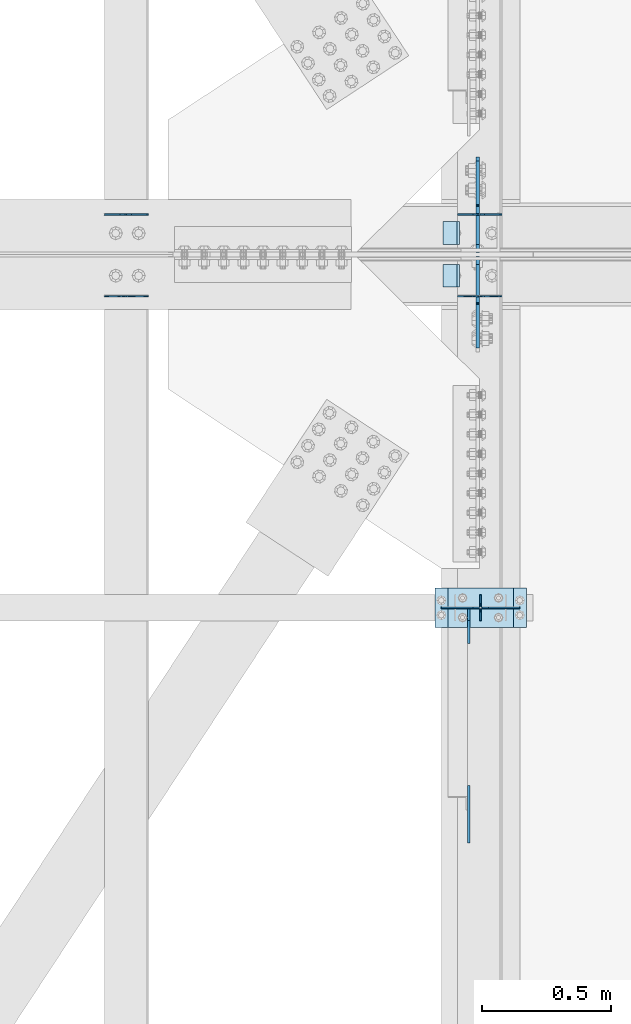
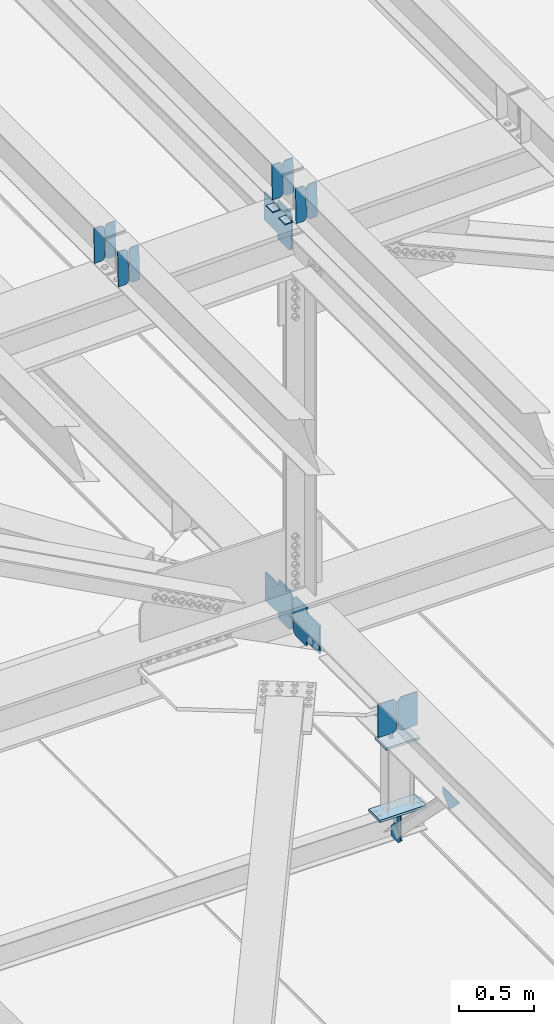
# One storey, part 3353 of 3843: 21 plates, 9 elements without a shape of their own.
"""IFC2X3 building model written with IfcOpenShell, lengths in millimetres."""

from ifc_helpers import new_model, si_unit, frame, origin_with_axes, place, context, subcontext, project, spatial, faceted_brep, material, type_object, element, aggregate, save


model = new_model("IFC2X3")

# Units and contexts
model_context = context("Model", 3, precision=1e-05, world=origin_with_axes())
body_context = subcontext(model_context, "Body", "Model", "MODEL_VIEW")
ifc_project = project(units=[si_unit("LENGTHUNIT", "METRE", prefix="MILLI"), si_unit("AREAUNIT", "SQUARE_METRE"), si_unit("VOLUMEUNIT", "CUBIC_METRE"), si_unit("MASSUNIT", "GRAM", prefix="KILO"), si_unit("TIMEUNIT", "SECOND"), si_unit("PLANEANGLEUNIT", "RADIAN"), si_unit("SOLIDANGLEUNIT", "STERADIAN"), si_unit("THERMODYNAMICTEMPERATUREUNIT", "DEGREE_CELSIUS"), si_unit("LUMINOUSINTENSITYUNIT", "LUMEN")], contexts=[model_context])

# Site, building, storey
site_placement = place(None, origin_with_axes())
site = spatial("IfcSite", under=ifc_project, at=site_placement, CompositionType="ELEMENT")
building_placement = place(site_placement, origin_with_axes())
building = spatial("IfcBuilding", under=site, at=building_placement, Name="Undefined", CompositionType="ELEMENT")
storey_placement = place(building_placement, origin_with_axes())
storey = spatial("IfcBuildingStorey", under=building, at=storey_placement, Name="Undefined", CompositionType="ELEMENT", Elevation=0.0)

# Assembly, plates
assembly_1_placement = place(storey_placement, origin_with_axes())
assembly_1 = element("IfcElementAssembly", 1, at=assembly_1_placement, inside=storey, Name="BEAM", AssemblyPlace="NOTDEFINED", PredefinedType="RIGID_FRAME")
ifc_material = material(Name="STEEL/A572-50")
plate_type_1 = type_object("IfcPlateType", PredefinedType="NOTDEFINED")
plate_1_placement = place(assembly_1_placement, frame((42144.6966582542, 67427.3134445784, 45577.8711481573), z_axis=(-0.0211520981215144, 0.000541454999853157, 0.999776122725254), x_axis=(-0.999776269355723, -1.23390000258365e-05, -0.0211520940075068)))
plate_1 = element("IfcPlate", 2, at=plate_1_placement, type_object=plate_type_1, material=ifc_material, Name="PLATE", context=body_context, shape_type="Brep", body=[
    faceted_brep([(0.0, -3.17499999999927, 0.0), (6.83940015733242e-10, -3.17499999996653, 288.924999998613), (6.54836185276508e-10, 3.17500000001746, 288.924999998591), (0.0, 3.17499999999927, 0.0), (60.3250007643655, -3.17500000017753, 288.924999998606), (60.3250007643219, 3.17499999979918, 288.924999998584), (79.3750000013097, -3.17500000025029, 269.875000761494), (79.375000001266, 3.17499999972642, 269.875000761487), (79.375000000713, -3.17500000026484, 19.0499992370605), (79.3750000006985, 3.17499999971187, 19.0499992370533), (60.325000763667, -3.17500000020664, -1.45519152283669e-11), (60.3250007636234, 3.17499999977736, -3.63797880709171e-11)], [[[0, 1, 2, 3]], [[1, 4, 5, 2]], [[4, 6, 7, 5]], [[6, 8, 9, 7]], [[8, 10, 11, 9]], [[10, 0, 3, 11]], [[5, 7, 9, 11, 3, 2]], [[10, 8, 6, 4, 1, 0]]]),
])
plate_2_placement = place(assembly_1_placement, frame((42058.9908375645, 67427.3124606707, 45576.0578848238), z_axis=(-0.0211520981215144, 0.000541454999853157, 0.999776122725254), x_axis=(-0.999776269355723, -1.23390000258365e-05, -0.0211520940075068)))
plate_2 = element("IfcPlate", 3, at=plate_2_placement, type_object=plate_type_1, material=ifc_material, Name="PLATE", context=body_context, shape_type="Brep", body=[
    faceted_brep([(4.36557456851006e-11, -3.17499999998836, 19.0499992370969), (6.11180439591408e-10, -3.17499999996653, 269.875000761516), (5.96628524363041e-10, 3.17500000001746, 269.875000761502), (1.45519152283669e-11, 3.17499999998836, 19.0499992370824), (19.0499992376572, -3.17500000003201, 288.924999998606), (19.0499992376281, 3.1749999999447, 288.924999998584), (79.3750000013242, -3.17500000025029, 288.924999998591), (79.3750000013097, 3.1749999997337, 288.92499999857), (79.3750000006548, -3.17500000026484, -2.18278728425503e-11), (79.3750000006403, 3.17499999969732, -2.91038304567337e-11), (19.0499992370023, -3.17500000005384, 0.0), (19.0499992369587, 3.17499999992287, -1.45519152283669e-11)], [[[0, 1, 2, 3]], [[1, 4, 5, 2]], [[4, 6, 7, 5]], [[6, 8, 9, 7]], [[8, 10, 11, 9]], [[10, 0, 3, 11]], [[5, 7, 9, 11, 3, 2]], [[10, 8, 6, 4, 1, 0]]]),
])

assembly_2_placement = place(storey_placement, origin_with_axes())
assembly_2 = element("IfcElementAssembly", 4, at=assembly_2_placement, inside=storey, Name="BEAM", AssemblyPlace="NOTDEFINED", PredefinedType="RIGID_FRAME")
plate_3_placement = place(assembly_2_placement, frame((42144.6966586276, 67109.9529261237, 45577.9672977628), z_axis=(-0.0211520980636923, 7.39979999707428e-05, 0.999776266607585), x_axis=(-0.999776269345987, -1.58399999781977e-06, -0.021152098007311)))
plate_3 = element("IfcPlate", 5, at=plate_3_placement, type_object=plate_type_1, material=ifc_material, Name="PLATE", context=body_context, shape_type="Brep", body=[
    faceted_brep([(0.0, -3.17499999999927, 0.0), (6.83940015733242e-10, -3.17499999996653, 288.924999998613), (6.54836185276508e-10, 3.17500000001746, 288.924999998591), (0.0, 3.17499999999927, 0.0), (60.3250007643655, -3.17500000017753, 288.924999998606), (60.3250007643219, 3.17499999979918, 288.924999998584), (79.3750000013097, -3.17500000025029, 269.875000761494), (79.375000001266, 3.17499999972642, 269.875000761487), (79.375000000713, -3.17500000026484, 19.0499992370605), (79.3750000006985, 3.17499999971187, 19.0499992370533), (60.325000763667, -3.17500000020664, -1.45519152283669e-11), (60.3250007636234, 3.17499999977736, -3.63797880709171e-11)], [[[0, 1, 2, 3]], [[1, 4, 5, 2]], [[4, 6, 7, 5]], [[6, 8, 9, 7]], [[8, 10, 11, 9]], [[10, 0, 3, 11]], [[5, 7, 9, 11, 3, 2]], [[10, 8, 6, 4, 1, 0]]]),
])
plate_4_placement = place(assembly_2_placement, frame((42058.9908379379, 67109.9527938003, 45576.1540341674), z_axis=(-0.0211520980636923, 7.39979999707428e-05, 0.999776266607585), x_axis=(-0.999776269345987, -1.58399999781977e-06, -0.021152098007311)))
plate_4 = element("IfcPlate", 6, at=plate_4_placement, type_object=plate_type_1, material=ifc_material, Name="PLATE", context=body_context, shape_type="Brep", body=[
    faceted_brep([(4.36557456851006e-11, -3.17499999998836, 19.0499992370969), (6.11180439591408e-10, -3.17499999996653, 269.875000761516), (5.96628524363041e-10, 3.17500000001746, 269.875000761502), (1.45519152283669e-11, 3.17499999998836, 19.0499992370824), (19.0499992376572, -3.17500000003201, 288.924999998606), (19.0499992376281, 3.1749999999447, 288.924999998584), (79.3750000013242, -3.17500000025029, 288.924999998591), (79.3750000013097, 3.1749999997337, 288.92499999857), (79.3750000006548, -3.17500000026484, -2.18278728425503e-11), (79.3750000006403, 3.17499999969732, -2.91038304567337e-11), (19.0499992370023, -3.17500000005384, 0.0), (19.0499992369587, 3.17499999992287, -1.45519152283669e-11)], [[[0, 1, 2, 3]], [[1, 4, 5, 2]], [[4, 6, 7, 5]], [[6, 8, 9, 7]], [[8, 10, 11, 9]], [[10, 0, 3, 11]], [[5, 7, 9, 11, 3, 2]], [[10, 8, 6, 4, 1, 0]]]),
])

assembly_3_placement = place(storey_placement, origin_with_axes())
assembly_3 = element("IfcElementAssembly", 7, at=assembly_3_placement, inside=storey, Name="BEAM", AssemblyPlace="NOTDEFINED", PredefinedType="RIGID_FRAME")
plate_5_placement = place(assembly_3_placement, frame((40773.0964783227, 67427.3529532861, 45541.7103920119), z_axis=(-0.0211520977781911, 0.00040906499986886, 0.999776185666276), x_axis=(-0.9997762693548, -8.33599996866193e-06, -0.0211520960075009)))
plate_5 = element("IfcPlate", 8, at=plate_5_placement, type_object=plate_type_1, material=ifc_material, Name="PLATE", context=body_context, shape_type="Brep", body=[
    faceted_brep([(0.0, -3.17499999999927, 0.0), (6.83940015733242e-10, -3.17499999996653, 288.924999998613), (6.54836185276508e-10, 3.17500000001746, 288.924999998591), (0.0, 3.17499999999927, 0.0), (60.3250007643655, -3.17500000017753, 288.924999998606), (60.3250007643219, 3.17499999979918, 288.924999998584), (79.3750000013097, -3.17500000025029, 269.875000761494), (79.375000001266, 3.17499999972642, 269.875000761487), (79.375000000713, -3.17500000026484, 19.0499992370605), (79.3750000006985, 3.17499999971187, 19.0499992370533), (60.325000763667, -3.17500000020664, -1.45519152283669e-11), (60.3250007636234, 3.17499999977736, -3.63797880709171e-11)], [[[0, 1, 2, 3]], [[1, 4, 5, 2]], [[4, 6, 7, 5]], [[6, 8, 9, 7]], [[8, 10, 11, 9]], [[10, 0, 3, 11]], [[5, 7, 9, 11, 3, 2]], [[10, 8, 6, 4, 1, 0]]]),
])
plate_6_placement = place(assembly_3_placement, frame((40687.390657633, 67427.3522113762, 45539.8971285628), z_axis=(-0.0211520977781911, 0.00040906499986886, 0.999776185666276), x_axis=(-0.9997762693548, -8.33599996866193e-06, -0.0211520960075009)))
plate_6 = element("IfcPlate", 9, at=plate_6_placement, type_object=plate_type_1, material=ifc_material, Name="PLATE", context=body_context, shape_type="Brep", body=[
    faceted_brep([(4.36557456851006e-11, -3.17499999998836, 19.0499992370969), (6.11180439591408e-10, -3.17499999996653, 269.875000761516), (5.96628524363041e-10, 3.17500000001746, 269.875000761502), (1.45519152283669e-11, 3.17499999998836, 19.0499992370824), (19.0499992376572, -3.17500000003201, 288.924999998606), (19.0499992376281, 3.1749999999447, 288.924999998584), (79.3750000013242, -3.17500000025029, 288.924999998591), (79.3750000013097, 3.1749999997337, 288.92499999857), (79.3750000006548, -3.17500000026484, -2.18278728425503e-11), (79.3750000006403, 3.17499999969732, -2.91038304567337e-11), (19.0499992370023, -3.17500000005384, 0.0), (19.0499992369587, 3.17499999992287, -1.45519152283669e-11)], [[[0, 1, 2, 3]], [[1, 4, 5, 2]], [[4, 6, 7, 5]], [[6, 8, 9, 7]], [[8, 10, 11, 9]], [[10, 0, 3, 11]], [[5, 7, 9, 11, 3, 2]], [[10, 8, 6, 4, 1, 0]]]),
])
aggregate(assembly_3, [plate_5, plate_6])

assembly_4_placement = place(storey_placement, origin_with_axes())
assembly_4 = element("IfcElementAssembly", 10, at=assembly_4_placement, inside=storey, Name="BEAM", AssemblyPlace="NOTDEFINED", PredefinedType="RIGID_FRAME")
plate_7_placement = place(assembly_4_placement, frame((40773.0964821393, 67109.9557470953, 45541.7844469644), z_axis=(-0.0211520980514033, 6.45460000159801e-05, 0.99977626726275), x_axis=(-0.999776269345987, -1.58399999781977e-06, -0.021152098007311)))
plate_7 = element("IfcPlate", 11, at=plate_7_placement, type_object=plate_type_1, material=ifc_material, Name="PLATE", context=body_context, shape_type="Brep", body=[
    faceted_brep([(0.0, -3.17499999999927, 0.0), (6.83940015733242e-10, -3.17499999996653, 288.924999998613), (6.54836185276508e-10, 3.17500000001746, 288.924999998591), (0.0, 3.17499999999927, 0.0), (60.3250007643655, -3.17500000017753, 288.924999998606), (60.3250007643219, 3.17499999979918, 288.924999998584), (79.3750000013097, -3.17500000025029, 269.875000761494), (79.375000001266, 3.17499999972642, 269.875000761487), (79.375000000713, -3.17500000026484, 19.0499992370605), (79.3750000006985, 3.17499999971187, 19.0499992370533), (60.325000763667, -3.17500000020664, -1.45519152283669e-11), (60.3250007636234, 3.17499999977736, -3.63797880709171e-11)], [[[0, 1, 2, 3]], [[1, 4, 5, 2]], [[4, 6, 7, 5]], [[6, 8, 9, 7]], [[8, 10, 11, 9]], [[10, 0, 3, 11]], [[5, 7, 9, 11, 3, 2]], [[10, 8, 6, 4, 1, 0]]]),
])
plate_8_placement = place(assembly_4_placement, frame((40687.3906614499, 67109.9556301145, 45539.9711833663), z_axis=(-0.0211520980514033, 6.45460000159801e-05, 0.99977626726275), x_axis=(-0.999776269345987, -1.58399999781977e-06, -0.021152098007311)))
plate_8 = element("IfcPlate", 12, at=plate_8_placement, type_object=plate_type_1, material=ifc_material, Name="PLATE", context=body_context, shape_type="Brep", body=[
    faceted_brep([(4.36557456851006e-11, -3.17499999998836, 19.0499992370969), (6.11180439591408e-10, -3.17499999996653, 269.875000761516), (5.96628524363041e-10, 3.17500000001746, 269.875000761502), (1.45519152283669e-11, 3.17499999998836, 19.0499992370824), (19.0499992376572, -3.17500000003201, 288.924999998606), (19.0499992376281, 3.1749999999447, 288.924999998584), (79.3750000013242, -3.17500000025029, 288.924999998591), (79.3750000013097, 3.1749999997337, 288.92499999857), (79.3750000006548, -3.17500000026484, -2.18278728425503e-11), (79.3750000006403, 3.17499999969732, -2.91038304567337e-11), (19.0499992370023, -3.17500000005384, 0.0), (19.0499992369587, 3.17499999992287, -1.45519152283669e-11)], [[[0, 1, 2, 3]], [[1, 4, 5, 2]], [[4, 6, 7, 5]], [[6, 8, 9, 7]], [[8, 10, 11, 9]], [[10, 0, 3, 11]], [[5, 7, 9, 11, 3, 2]], [[10, 8, 6, 4, 1, 0]]]),
])
aggregate(assembly_4, [plate_7, plate_8])

assembly_5_placement = place(storey_placement, origin_with_axes())
assembly_5 = element("IfcElementAssembly", 13, at=assembly_5_placement, inside=storey, Name="BEAM", AssemblyPlace="NOTDEFINED", PredefinedType="RIGID_FRAME")
plate_type_2 = type_object("IfcPlateType", PredefinedType="NOTDEFINED")
plate_9_placement = place(assembly_5_placement, frame((42062.4, 65849.5, 41495.6625), z_axis=(0.0, 0.0, -1.0), x_axis=(0.0, 1.0, 0.0)))
plate_9 = element("IfcPlate", 14, at=plate_9_placement, type_object=plate_type_2, material=ifc_material, Name="PLATE", context=body_context, shape_type="Brep", body=[
    faceted_brep([(0.0, -3.17499999999927, 0.0), (0.0, -3.17500000000291, 187.324999999997), (0.0, 3.17500000000291, 187.324999999997), (0.0, 3.17499999999927, 0.0), (34.9250001907349, -3.17500000000291, 187.324999999997), (34.9250001907349, 3.17500000000291, 187.324999999997), (47.625, -3.17500000000291, 174.625000190732), (47.625, 3.17500000000291, 174.625000190732), (47.625, -3.17499999999927, 12.6999998092651), (47.625, 3.17499999999927, 12.6999998092651), (34.9250001907349, -3.17499999999927, 0.0), (34.9250001907349, 3.17499999999927, 0.0)], [[[0, 1, 2, 3]], [[1, 4, 5, 2]], [[4, 6, 7, 5]], [[6, 8, 9, 7]], [[8, 10, 11, 9]], [[10, 0, 3, 11]], [[5, 7, 9, 11, 3, 2]], [[10, 8, 6, 4, 1, 0]]]),
])
plate_10_placement = place(assembly_5_placement, frame((42062.4, 65951.1, 41495.6625), z_axis=(0.0, 0.0, -1.0), x_axis=(0.0, -1.0, 0.0)))
plate_10 = element("IfcPlate", 15, at=plate_10_placement, type_object=plate_type_2, material=ifc_material, Name="PLATE", context=body_context, shape_type="Brep", body=[
    faceted_brep([(0.0, -3.17499999999927, 0.0), (0.0, -3.17500000000291, 187.324999999997), (0.0, 3.17500000000291, 187.324999999997), (0.0, 3.17499999999927, 0.0), (34.9250001907349, -3.17500000000291, 187.324999999997), (34.9250001907349, 3.17500000000291, 187.324999999997), (47.625, -3.17500000000291, 174.625000190732), (47.625, 3.17500000000291, 174.625000190732), (47.625, -3.17499999999927, 12.6999998092651), (47.625, 3.17499999999927, 12.6999998092651), (34.9250001907349, -3.17499999999927, 0.0), (34.9250001907349, 3.17499999999927, 0.0)], [[[0, 1, 2, 3]], [[1, 4, 5, 2]], [[4, 6, 7, 5]], [[6, 8, 9, 7]], [[8, 10, 11, 9]], [[10, 0, 3, 11]], [[5, 7, 9, 11, 3, 2]], [[10, 8, 6, 4, 1, 0]]]),
])

# Plate
plate_type_3 = type_object("IfcPlateType", PredefinedType="NOTDEFINED")
plate_11_placement = place(assembly_1_placement, frame((41979.7679149656, 67398.8999999999, 45568.1145469911), z_axis=(0.0, -1.0, 0.0), x_axis=(-0.999776270257024, 0.0, -0.0211520550054595)))
plate_11 = element("IfcPlate", 16, at=plate_11_placement, type_object=plate_type_3, material=ifc_material, Name="PLATE", context=body_context, shape_type="Brep", body=[
    faceted_brep([(9.52499999982683, -4.7625000001135, 88.8999999999942), (0.0, 4.76249999999709, 88.9000015258789), (0.0, 4.76249999999709, 0.0), (9.52499999981956, -4.76249999999709, 0.0), (63.4999984608512, -4.76249999988795, 88.8999999999796), (63.4999984608367, -4.76249999988795, -1.45519152283669e-11), (63.4999984608221, 4.76250000013533, -1.45519152283669e-11), (63.4999984608367, 4.76250000013533, 88.8999999999796)], [[[0, 1, 2, 3]], [[4, 5, 6, 7]], [[5, 4, 0, 3]], [[6, 5, 3, 2]], [[7, 6, 2, 1]], [[4, 7, 1, 0]]]),
])

aggregate(assembly_1, [plate_1, plate_2, plate_11])

plate_12_placement = place(assembly_2_placement, frame((41979.7679149656, 67233.8000015258, 45568.1145469911), z_axis=(0.0, -1.0, 0.0), x_axis=(-0.999776270257024, 0.0, -0.0211520550054595)))
plate_12 = element("IfcPlate", 17, at=plate_12_placement, type_object=plate_type_3, material=ifc_material, Name="PLATE", context=body_context, shape_type="Brep", body=[
    faceted_brep([(9.52499999982683, -4.7625000001135, 88.8999999999942), (0.0, 4.76249999999709, 88.9000015258789), (0.0, 4.76249999999709, 0.0), (9.52499999981956, -4.76249999999709, 0.0), (63.4999984608512, -4.76249999988795, 88.8999999999796), (63.4999984608367, -4.76249999988795, -1.45519152283669e-11), (63.4999984608221, 4.76250000013533, -1.45519152283669e-11), (63.4999984608367, 4.76250000013533, 88.8999999999796)], [[[0, 1, 2, 3]], [[4, 5, 6, 7]], [[5, 4, 0, 3]], [[6, 5, 3, 2]], [[7, 6, 2, 1]], [[4, 7, 1, 0]]]),
])

aggregate(assembly_2, [plate_3, plate_4, plate_12])

# Assembly, plates
assembly_6_placement = place(storey_placement, origin_with_axes())
assembly_6 = element("IfcElementAssembly", 18, at=assembly_6_placement, inside=storey, Name="BEAM", AssemblyPlace="NOTDEFINED", PredefinedType="RIGID_FRAME")
plate_type_4 = type_object("IfcPlateType", PredefinedType="NOTDEFINED")
plate_13_placement = place(assembly_6_placement, frame((42051.2875706179, 67264.7562501487, 42150.1181134752), z_axis=(0.0, -0.707106781186682, 0.707106781186413), x_axis=(0.0, -0.707106781186548, -0.707106781186548)))
plate_13 = element("IfcPlate", 19, at=plate_13_placement, type_object=plate_type_4, material=ifc_material, Name="PLATE", context=body_context, shape_type="Brep", body=[
    faceted_brep([(0.0, -6.3499999046162, 0.0), (-179.562537390302, -6.34999999999854, 179.562537390342), (-179.562537390302, 6.34999999999854, 179.562537390342), (7.27595761418343e-12, 6.3499999046162, 0.0), (-179.562537389822, -6.34999999999854, 224.46381799594), (-179.562537389822, 6.34999999999854, 224.46381799594), (-75.7283257224772, -6.34999999999854, 328.298029663278), (-75.7283257224772, 6.34999999999854, 328.298029663278), (-53.3518648519821, -6.34999999999854, 305.921568792786), (-53.3518648519821, 6.34999999999854, 305.921568792786), (-49.2316883838357, -6.34999999999854, 303.168554892323), (-49.2316883838357, 6.34999999999854, 303.168554892323), (-44.371608865782, -6.34999999999854, 302.201824969758), (-44.371608865782, 6.34999999999854, 302.201824969758), (-39.5115293477138, -6.34999999999854, 303.168554892374), (-39.5115293477138, 6.34999999999854, 303.168554892374), (-35.3913528795383, -6.34999999999854, 305.921568792881), (-35.3913528795383, 6.34999999999854, 305.921568792881), (81.3519765653036, -6.34999999999854, 422.66489823769), (81.3519765653036, 6.34999999999854, 422.66489823769), (242.996586743742, -6.34999999999854, 261.020288059208), (242.996586743742, 6.34999999999854, 261.020288059208), (126.2532572989, -6.34999999999854, 144.276958614395), (126.2532572989, 6.34999999999854, 144.276958614395), (123.500243398405, -6.34999999999854, 140.156782146212), (123.500243398405, 6.34999999999854, 140.156782146212), (122.533513475792, -6.34999999999854, 135.296702628159), (122.533513475792, 6.34999999999854, 135.296702628159), (123.500243398361, -6.34999999999854, 130.436623110098), (123.500243398361, 6.34999999999854, 130.436623110098), (126.253257298828, -6.34999999999854, 126.316446641958), (126.253257298828, 6.34999999999854, 126.316446641958), (148.735492004496, -6.35000000000582, 103.834211399357), (148.735492004496, 6.35000000000582, 103.834211399357), (44.9012806051323, -6.35000000000582, -1.45519152283669e-11), (44.9012806051323, 6.35000000000582, -1.45519152283669e-11)], [[[0, 1, 2, 3]], [[1, 4, 5, 2]], [[4, 6, 7, 5]], [[6, 8, 9, 7]], [[8, 10, 11, 9]], [[10, 12, 13, 11]], [[12, 14, 15, 13]], [[14, 16, 17, 15]], [[16, 18, 19, 17]], [[18, 20, 21, 19]], [[20, 22, 23, 21]], [[22, 24, 25, 23]], [[24, 26, 27, 25]], [[26, 28, 29, 27]], [[28, 30, 31, 29]], [[30, 32, 33, 31]], [[32, 34, 35, 33]], [[34, 0, 3, 35]], [[5, 7, 9, 11, 13, 15, 17, 19, 21, 23, 25, 27, 29, 31, 33, 35, 3, 2]], [[34, 32, 30, 28, 26, 24, 22, 20, 18, 16, 14, 12, 10, 8, 6, 4, 1, 0]]]),
])
plate_14_placement = place(assembly_6_placement, frame((42051.2874999618, 67279.04375, 42150.1181131164), z_axis=(0.0, 0.707106781186548, 0.707106781186548), x_axis=(5.70000238222118e-08, 0.707106781186546, -0.707106781186546)))
plate_14 = element("IfcPlate", 20, at=plate_14_placement, type_object=plate_type_4, material=ifc_material, Name="PLATE", context=body_context, shape_type="Brep", body=[
    faceted_brep([(0.0, -6.3499999046162, 0.0), (-179.562537390302, -6.34999999999854, 179.562537390342), (-179.562537390302, 6.34999999999854, 179.562537390342), (7.27595761418343e-12, 6.3499999046162, 0.0), (-179.562537389822, -6.34999999999854, 224.46381799594), (-179.562537389822, 6.34999999999854, 224.46381799594), (-75.7283257224772, -6.34999999999854, 328.298029663278), (-75.7283257224772, 6.34999999999854, 328.298029663278), (-53.246522594538, -6.34999999999854, 305.816226003648), (-53.246522594538, 6.34999999999854, 305.816226003648), (-49.1263461263989, -6.34999999999854, 303.063212103167), (-49.1263461263989, 6.34999999999854, 303.063212103167), (-44.2662666083306, -6.34999999999854, 302.096482180612), (-44.2662666083306, 6.34999999999854, 302.096482180612), (-39.4061870902842, -6.34999999999854, 303.063212103225), (-39.4061870902842, 6.34999999999854, 303.063212103225), (-35.2860106220942, -6.34999999999854, 305.81622600375), (-35.2860106220942, 6.34999999999854, 305.81622600375), (81.4573190885676, -6.34999999999854, 422.559555714412), (81.4573190885676, 6.34999999999854, 422.559555714412), (243.101929267043, -6.34999999999854, 260.914945535929), (243.101929267043, 6.34999999999854, 260.914945535929), (126.358599556366, -6.34999999999854, 144.171615825253), (126.358599556366, 6.34999999999854, 144.171615825253), (123.605585655856, -6.34999999999854, 140.051439357077), (123.605585655856, 6.34999999999854, 140.051439357077), (122.638855733258, -6.34999999999854, 135.191359839024), (122.638855733258, 6.34999999999854, 135.191359839024), (123.605585655812, -6.34999999999854, 130.331280320956), (123.605585655812, 6.34999999999854, 130.331280320956), (126.358599556286, -6.34999999999854, 126.211103852824), (126.358599556286, 6.34999999999854, 126.211103852824), (148.735492004496, -6.35000000000582, 103.834211399357), (148.735492004496, 6.35000000000582, 103.834211399357), (44.9012806051323, -6.35000000000582, -1.45519152283669e-11), (44.9012806051323, 6.35000000000582, -1.45519152283669e-11)], [[[0, 1, 2, 3]], [[1, 4, 5, 2]], [[4, 6, 7, 5]], [[6, 8, 9, 7]], [[8, 10, 11, 9]], [[10, 12, 13, 11]], [[12, 14, 15, 13]], [[14, 16, 17, 15]], [[16, 18, 19, 17]], [[18, 20, 21, 19]], [[20, 22, 23, 21]], [[22, 24, 25, 23]], [[24, 26, 27, 25]], [[26, 28, 29, 27]], [[28, 30, 31, 29]], [[30, 32, 33, 31]], [[32, 34, 35, 33]], [[34, 0, 3, 35]], [[5, 7, 9, 11, 13, 15, 17, 19, 21, 23, 25, 27, 29, 31, 33, 35, 3, 2]], [[34, 32, 30, 28, 26, 24, 22, 20, 18, 16, 14, 12, 10, 8, 6, 4, 1, 0]]]),
])
aggregate(assembly_6, [plate_13, plate_14])

# Assembly, plate
assembly_7_placement = place(storey_placement, origin_with_axes())
assembly_7 = element("IfcElementAssembly", 21, at=assembly_7_placement, inside=storey, Name="BEAM", AssemblyPlace="NOTDEFINED", PredefinedType="RIGID_FRAME")
plate_15_placement = place(assembly_7_placement, frame((42051.2875912749, 67283.0125003841, 45240.956118967), z_axis=(0.0, 0.707106781186548, 0.707106781186548), x_axis=(5.70000238222118e-08, 0.707106781186546, -0.707106781186546)))
plate_15 = element("IfcPlate", 22, at=plate_15_placement, type_object=plate_type_4, material=ifc_material, Name="PLATE", context=body_context, shape_type="Brep", body=[
    faceted_brep([(0.0, -6.3499999046162, 0.0), (-179.447841212437, -6.34999999999854, 179.44784121275), (-179.447841212437, 6.34999999999854, 179.44784121275), (7.27595761418343e-12, 6.3499999046162, 0.0), (-179.447841212386, -6.34999999999854, 224.349121818348), (-179.447841212386, 6.34999999999854, 224.349121818348), (-68.3171717070836, -6.34999999999854, 335.479791324615), (-68.3171717070836, 6.34999999999854, 335.479791324615), (-46.0540442231213, -6.34999999999854, 313.216663840605), (-46.0540442231213, 6.34999999999854, 313.216663840605), (-41.9338677549604, -6.34999999999854, 310.463649940139), (-41.9338677549604, 6.34999999999854, 310.463649940139), (-37.0737882368776, -6.34999999999854, 309.496920017584), (-37.0737882368776, 6.34999999999854, 309.496920017584), (-32.2137087188094, -6.34999999999854, 310.463649940211), (-32.2137087188094, 6.34999999999854, 310.463649940211), (-28.093532250623, -6.34999999999854, 313.216663840736), (-28.093532250623, 6.34999999999854, 313.216663840736), (88.6497974512677, -6.34999999999854, 429.959993543627), (88.6497974512677, 6.34999999999854, 429.959993543627), (250.29440763043, -6.34999999999854, 268.315383364199), (250.29440763043, 6.34999999999854, 268.315383364199), (133.551077928434, -6.34999999999854, 151.572053661192), (133.551077928434, 6.34999999999854, 151.572053661192), (130.798064027949, -6.34999999999854, 147.451877193031), (130.798064027949, 6.34999999999854, 147.451877193031), (129.831334105351, -6.34999999999854, 142.591797674977), (129.831334105351, 6.34999999999854, 142.591797674977), (130.798064027909, -6.34999999999854, 137.731718156923), (130.798064027909, 6.34999999999854, 137.731718156923), (133.551077928372, -6.34999999999854, 133.611541688806), (133.551077928372, 6.34999999999854, 133.611541688806), (156.031950102829, -6.35000000000582, 111.130669497703), (156.031950102829, 6.35000000000582, 111.130669497703), (44.9012806051323, -6.35000000000582, -1.45519152283669e-11), (44.9012806051323, 6.35000000000582, -1.45519152283669e-11)], [[[0, 1, 2, 3]], [[1, 4, 5, 2]], [[4, 6, 7, 5]], [[6, 8, 9, 7]], [[8, 10, 11, 9]], [[10, 12, 13, 11]], [[12, 14, 15, 13]], [[14, 16, 17, 15]], [[16, 18, 19, 17]], [[18, 20, 21, 19]], [[20, 22, 23, 21]], [[22, 24, 25, 23]], [[24, 26, 27, 25]], [[26, 28, 29, 27]], [[28, 30, 31, 29]], [[30, 32, 33, 31]], [[32, 34, 35, 33]], [[34, 0, 3, 35]], [[5, 7, 9, 11, 13, 15, 17, 19, 21, 23, 25, 27, 29, 31, 33, 35, 3, 2]], [[34, 32, 30, 28, 26, 24, 22, 20, 18, 16, 14, 12, 10, 8, 6, 4, 1, 0]]]),
])
aggregate(assembly_7, [plate_15])

# Assembly, plates
assembly_8_placement = place(storey_placement, origin_with_axes())
assembly_8 = element("IfcElementAssembly", 23, at=assembly_8_placement, inside=storey, Name="POST", AssemblyPlace="NOTDEFINED", PredefinedType="RIGID_FRAME")
plate_type_5 = type_object("IfcPlateType", PredefinedType="NOTDEFINED")
plate_16_placement = place(assembly_8_placement, frame((41935.3999969017, 65976.4992628729, 42083.0375000284), z_axis=(0.0, -0.999999997006942, 7.73699999990641e-05), x_axis=(1.0, 0.0, 0.0)))
plate_16 = element("IfcPlate", 24, at=plate_16_placement, type_object=plate_type_5, material=ifc_material, Name="PLATE", context=body_context, shape_type="Brep", body=[
    faceted_brep([(0.0, -9.52500000000146, 0.0), (0.0, -9.5249999999287, 152.40000000162), (0.0, 9.52500000002328, 152.40000000162), (0.0, 9.52500000000146, 0.0), (254.0, -9.5249999999287, 152.40000000162), (254.0, 9.52500000002328, 152.40000000162), (253.999999999998, -9.52500000000146, 0.0), (253.999999999998, 9.52500000000146, 0.0)], [[[0, 1, 2, 3]], [[1, 4, 5, 2]], [[4, 6, 7, 5]], [[6, 0, 3, 7]], [[5, 7, 3, 2]], [[6, 4, 1, 0]]]),
])
plate_17_placement = place(assembly_8_placement, frame((42240.2, 65824.1, 41513.125), z_axis=(-1.0, 0.0, 0.0), x_axis=(0.0, 1.0, 0.0)))
plate_17 = element("IfcPlate", 25, at=plate_17_placement, type_object=plate_type_5, material=ifc_material, Name="PLATE", context=body_context, shape_type="Brep", body=[
    faceted_brep([(0.0, -9.52500000000146, 0.0), (0.0, -9.52500000000146, 355.599999999999), (0.0, 9.52500000000146, 355.599999999999), (0.0, 9.52500000000146, 0.0), (152.399999999994, -9.52500000000146, 355.599999999999), (152.399999999994, 9.52500000000146, 355.599999999999), (152.400000000001, -9.52500000000146, 0.0), (152.400000000001, 9.52500000000146, 0.0)], [[[0, 1, 2, 3]], [[1, 4, 5, 2]], [[4, 6, 7, 5]], [[6, 0, 3, 7]], [[5, 7, 3, 2]], [[6, 4, 1, 0]]]),
])
aggregate(assembly_8, [plate_16, plate_17])

# Assembly, plate
assembly_9_placement = place(storey_placement, origin_with_axes())
assembly_9 = element("IfcElementAssembly", 26, at=assembly_9_placement, inside=storey, Name="BEAM", AssemblyPlace="NOTDEFINED", PredefinedType="RIGID_FRAME")
plate_type_6 = type_object("IfcPlateType", PredefinedType="NOTDEFINED")
plate_18_placement = place(assembly_9_placement, frame((42016.3625, 64987.4776850995, 42123.3262923132), z_axis=(0.0, 0.707106781186548, 0.707106781186548), x_axis=(5.70000238222118e-08, 0.707106781186546, -0.707106781186546)))
plate_18 = element("IfcPlate", 27, at=plate_18_placement, type_object=plate_type_6, material=ifc_material, Name="PLATE", context=body_context, shape_type="Brep", body=[
    faceted_brep([(0.0, -4.76249999999709, 0.0), (157.726597423803, -4.76249999999709, 157.726601438866), (157.726597423803, 4.76249999999709, 157.726601438866), (0.0, 4.76249999999709, 0.0), (188.387110059113, -4.76249999999709, 127.066089584019), (188.387110059113, 4.76249999999709, 127.066089584019), (188.387111679331, -4.76249999999709, 1.09139364212751e-10), (188.387111679331, 4.76249999999709, 1.09139364212751e-10)], [[[0, 1, 2, 3]], [[1, 4, 5, 2]], [[4, 6, 7, 5]], [[6, 0, 3, 7]], [[5, 7, 3, 2]], [[6, 4, 1, 0]]]),
])

# Plate
plate_type_7 = type_object("IfcPlateType", PredefinedType="NOTDEFINED")
plate_19_placement = place(assembly_5_placement, frame((42016.3625, 65897.1250000139, 41306.750000025), z_axis=(0.0, -1.0, 0.0), x_axis=(0.0, 0.0, 1.0)))
plate_19 = element("IfcPlate", 28, at=plate_19_placement, type_object=plate_type_7, material=ifc_material, Name="PLATE", context=body_context, shape_type="Brep", body=[
    faceted_brep([(0.0, -4.76250000000073, 12.6999998092651), (4.450703272596e-08, -4.76249999999709, 93.0710244828806), (4.450703272596e-08, 4.76249999999709, 93.0710244828806), (0.0, 4.76250000000073, 12.6999998092651), (43.3137807601452, -4.76249999999709, 136.384805065652), (43.3137807601452, 4.76249999999709, 136.384805065652), (133.209805202001, -4.76249999999709, 46.4887805392646), (133.209805202001, 4.76249999999709, 46.4887805392646), (86.7210245267561, -4.76249999999709, 0.0), (86.7210245267561, 4.76249999999709, 0.0), (12.6999998092651, -4.76250000000073, 0.0), (12.6999998092651, 4.76250000000073, 0.0)], [[[0, 1, 2, 3]], [[1, 4, 5, 2]], [[4, 6, 7, 5]], [[6, 8, 9, 7]], [[8, 10, 11, 9]], [[10, 0, 3, 11]], [[5, 7, 9, 11, 3, 2]], [[10, 8, 6, 4, 1, 0]]]),
])

aggregate(assembly_5, [plate_19, plate_9, plate_10])

plate_type_8 = type_object("IfcPlateType", PredefinedType="NOTDEFINED")
plate_20_placement = place(assembly_9_placement, frame((42214.8, 65900.3224771045, 42413.7751216454), z_axis=(0.0, -7.73699999990641e-05, -0.999999997006942), x_axis=(-1.0, 0.0, 0.0)))
plate_20 = element("IfcPlate", 29, at=plate_20_placement, type_object=plate_type_8, material=ifc_material, Name="PLATE", context=body_context, shape_type="Brep", body=[
    faceted_brep([(0.0, -3.17499999999927, 0.0), (0.0, -3.17500000007567, 273.049999997937), (0.0, 3.17499999993743, 273.049999997937), (0.0, 3.17499999999927, 0.0), (122.237500389827, -3.17500000007567, 273.049999997937), (122.237500389827, 3.17499999993743, 273.049999997937), (147.637500008357, -3.17500000006476, 247.650000379464), (147.637500008357, 3.17499999994106, 247.650000379464), (147.637500008357, -3.17500000001382, 25.3999996184648), (147.637500008357, 3.17499999999927, 25.3999996184648), (122.237500389827, -3.17500000000291, 0.0), (122.237500389827, 3.17500000000291, -7.27595761418343e-12)], [[[0, 1, 2, 3]], [[1, 4, 5, 2]], [[4, 6, 7, 5]], [[6, 8, 9, 7]], [[8, 10, 11, 9]], [[10, 0, 3, 11]], [[5, 7, 9, 11, 3, 2]], [[10, 8, 6, 4, 1, 0]]]),
])

plate_21_placement = place(assembly_9_placement, frame((41910.0, 65900.3224770537, 42413.7751216454), z_axis=(0.0, -7.73699999990641e-05, -0.999999997006942), x_axis=(1.0, 0.0, 0.0)))
plate_21 = element("IfcPlate", 30, at=plate_21_placement, type_object=plate_type_8, material=ifc_material, Name="PLATE", context=body_context, shape_type="Brep", body=[
    faceted_brep([(0.0, -3.17499999999927, 0.0), (0.0, -3.17500000007567, 273.049999997937), (0.0, 3.17499999993743, 273.049999997937), (0.0, 3.17499999999927, 0.0), (122.237500389827, -3.17500000007567, 273.049999997937), (122.237500389827, 3.17499999993743, 273.049999997937), (147.637500008357, -3.17500000006476, 247.650000379464), (147.637500008357, 3.17499999994106, 247.650000379464), (147.637500008357, -3.17500000001382, 25.3999996184648), (147.637500008357, 3.17499999999927, 25.3999996184648), (122.237500389827, -3.17500000000291, 0.0), (122.237500389827, 3.17500000000291, -7.27595761418343e-12)], [[[0, 1, 2, 3]], [[1, 4, 5, 2]], [[4, 6, 7, 5]], [[6, 8, 9, 7]], [[8, 10, 11, 9]], [[10, 0, 3, 11]], [[5, 7, 9, 11, 3, 2]], [[10, 8, 6, 4, 1, 0]]]),
])

aggregate(assembly_9, [plate_18, plate_20, plate_21])

save(model, "model.ifc")
